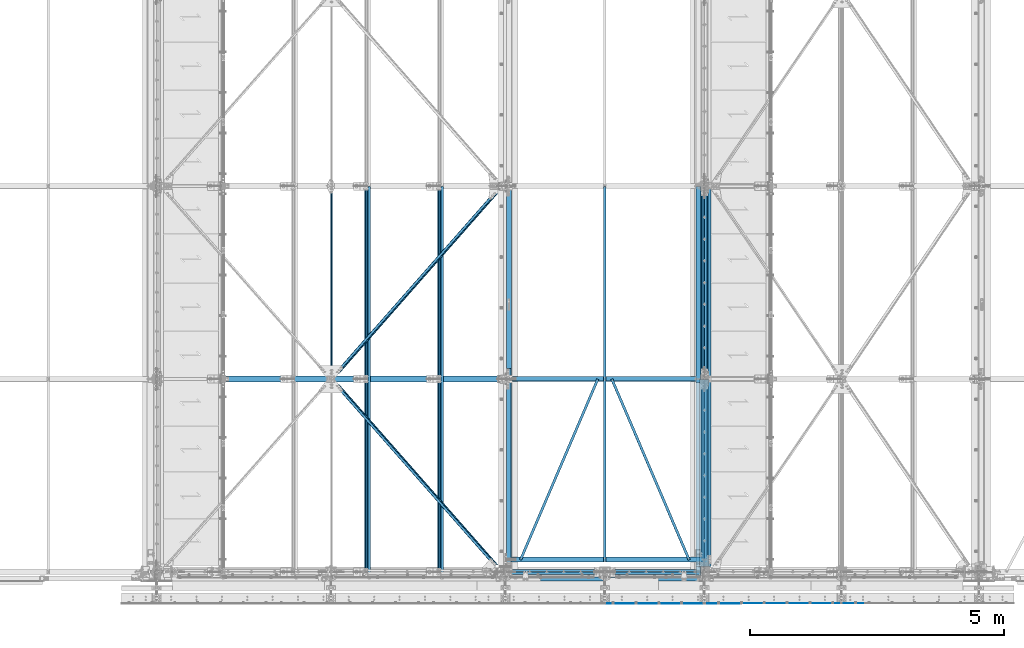
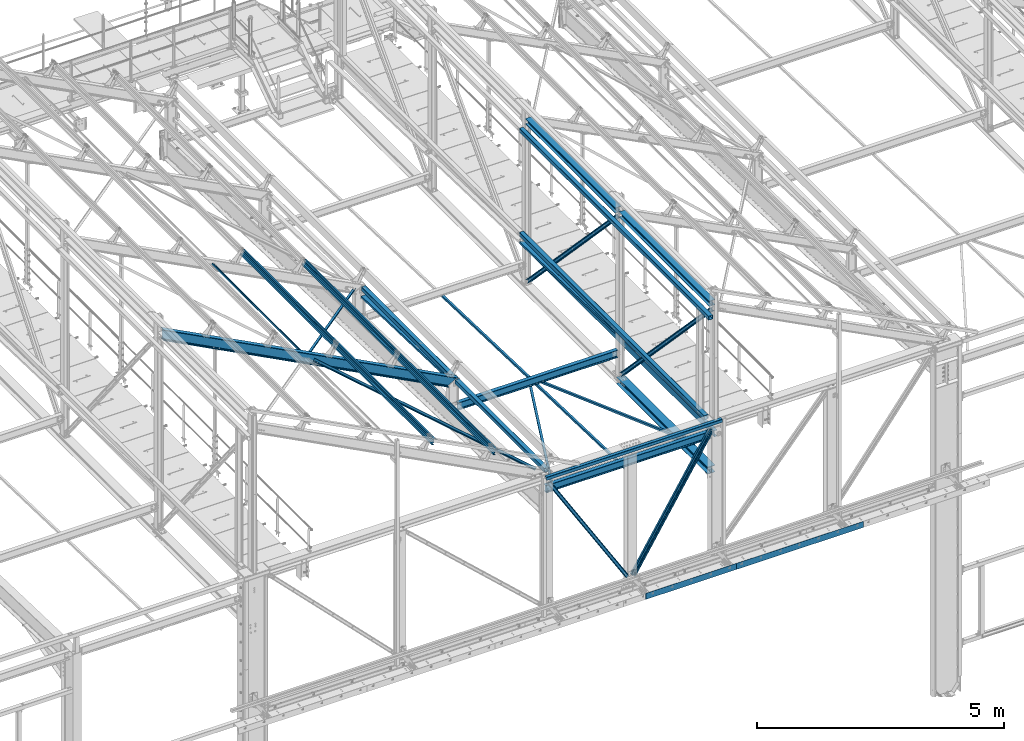
# One storey, part 47 of 496: 23 beams, 9 members, 32 elements without a shape of their own.
"""IFC2X3 building model written with IfcOpenShell, lengths in millimetres."""

from ifc_helpers import new_model, si_unit, frame, origin_with_axes, origin_2d_with_axis, place, context, subcontext, project, spatial, polyline, rectangle, hollow_rectangle, i_section, l_section, u_section, outline, extrude, clip, halfspace, material, type_object, element, aggregate, save


model = new_model("IFC2X3")

# Units and contexts
model_context = context("Model", 3, precision=1e-05, world=origin_with_axes())
body_context = subcontext(model_context, "Body", "Model", "MODEL_VIEW")
ifc_project = project(units=[si_unit("LENGTHUNIT", "METRE", prefix="MILLI"), si_unit("AREAUNIT", "SQUARE_METRE"), si_unit("VOLUMEUNIT", "CUBIC_METRE"), si_unit("MASSUNIT", "GRAM", prefix="KILO"), si_unit("TIMEUNIT", "SECOND"), si_unit("PLANEANGLEUNIT", "RADIAN"), si_unit("SOLIDANGLEUNIT", "STERADIAN"), si_unit("THERMODYNAMICTEMPERATUREUNIT", "DEGREE_CELSIUS"), si_unit("LUMINOUSINTENSITYUNIT", "LUMEN")], contexts=[model_context])

# Site, building, storey
site_placement = place(None, origin_with_axes())
site = spatial("IfcSite", under=ifc_project, at=site_placement, CompositionType="ELEMENT")
building_placement = place(site_placement, origin_with_axes())
building = spatial("IfcBuilding", under=site, at=building_placement, Name="Undefined", CompositionType="ELEMENT")
storey_placement = place(building_placement, origin_with_axes())
storey = spatial("IfcBuildingStorey", under=building, at=storey_placement, Name="Undefined", CompositionType="ELEMENT", Elevation=0.0)

# Assembly, beam
assembly_1_placement = place(storey_placement, origin_with_axes())
assembly_1 = element("IfcElementAssembly", 1, at=assembly_1_placement, inside=storey, AssemblyPlace="NOTDEFINED", PredefinedType="NOTDEFINED")
ifc_material_1 = material(Name="Undefined/S235-E24")
beam_type_1 = type_object("IfcBeamType", PredefinedType="NOTDEFINED")
beam_1_placement = place(assembly_1_placement, frame((19848.2097133607, 235.976054337025, 7837.48629341101), z_axis=(0.919534207042302, -0.392816044708112, 0.012344921990827), x_axis=(0.39300997707321, 0.919080459171206, -0.0288836890053805)))
beam_1 = element("IfcBeam", 2, at=beam_1_placement, type_object=beam_type_1, material=ifc_material_1, context=body_context, shape_type="SweptSolid", body=[
    extrude(l_section(Depth=50.0, Width=50.0, Thickness=5.0, FilletRadius=7.0, EdgeRadius=3.5, at=origin_2d_with_axis()), frame((3876.69700077137, -1.34499945929739e-14, -3.40701718119049e-12), z_axis=(-1.0, 0.0, 0.0), x_axis=(0.0, -1.0, 0.0)), (0.0, 0.0, 1.0), 3876.7),
])
aggregate(assembly_1, [beam_1])

assembly_2_placement = place(storey_placement, origin_with_axes())
assembly_2 = element("IfcElementAssembly", 3, at=assembly_2_placement, inside=storey, AssemblyPlace="NOTDEFINED", PredefinedType="NOTDEFINED")
beam_2_placement = place(assembly_2_placement, frame((23171.7903119741, 235.976054737208, 7837.48629340527), z_axis=(0.919534207042302, 0.392816044708111, -0.0123449219908271), x_axis=(-0.39300997707321, 0.919080459171207, -0.0288836890053805)))
beam_2 = element("IfcBeam", 4, at=beam_2_placement, type_object=beam_type_1, material=ifc_material_1, context=body_context, shape_type="SweptSolid", body=[
    extrude(l_section(Depth=50.0, Width=50.0, Thickness=5.0, FilletRadius=7.0, EdgeRadius=3.5, at=origin_2d_with_axis()), frame((3876.69700077137, -1.34499945929739e-14, -3.40701718119049e-12), z_axis=(-1.0, 0.0, 0.0), x_axis=(0.0, -1.0, 0.0)), (0.0, 0.0, 1.0), 3876.7),
])
aggregate(assembly_2, [beam_2])

assembly_3_placement = place(storey_placement, origin_with_axes())
assembly_3 = element("IfcElementAssembly", 5, at=assembly_3_placement, inside=storey, AssemblyPlace="NOTDEFINED", PredefinedType="NOTDEFINED")
beam_3_placement = place(assembly_3_placement, frame((21507.0000126668, 193.083339984078, 7838.83427099067), z_axis=(1.0, 0.0, 0.0), x_axis=(0.0, 0.999506556345274, -0.0314108870109058)))
beam_3 = element("IfcBeam", 6, at=beam_3_placement, type_object=beam_type_1, material=ifc_material_1, context=body_context, shape_type="SweptSolid", body=[
    extrude(l_section(Depth=50.0, Width=50.0, Thickness=5.0, FilletRadius=7.0, EdgeRadius=3.5, at=origin_2d_with_axis()), frame((7401.95936429781, -5.13614107098951e-14, 0.0), z_axis=(-1.0, 0.0, 0.0), x_axis=(0.0, -1.0, 0.0)), (0.0, 0.0, 1.0), 7401.96),
])
aggregate(assembly_3, [beam_3])

assembly_4_placement = place(storey_placement, origin_with_axes())
assembly_4 = element("IfcElementAssembly", 7, at=assembly_4_placement, inside=storey, AssemblyPlace="NOTDEFINED", PredefinedType="NOTDEFINED")
beam_type_2 = type_object("IfcBeamType", PredefinedType="NOTDEFINED")
beam_4_placement = place(assembly_4_placement, frame((19477.1831031286, 7597.88523553888, 8549.29591306557), z_axis=(0.46352885499701, 6.99999093634976e-09, 0.886081824994261), x_axis=(-0.624617894277257, -0.709285753314833, 0.326750985145042)))
beam_4 = element("IfcBeam", 8, at=beam_4_placement, type_object=beam_type_2, material=ifc_material_1, context=body_context, shape_type="Clipping", body=[
    clip(clip(extrude(l_section(Depth=60.0, Width=60.0, Thickness=6.0, FilletRadius=8.0, EdgeRadius=4.0, at=origin_2d_with_axis()), frame((5278.55461629117, -2.34983368195919e-13, 0.0), z_axis=(-1.0, 0.0, 0.0), x_axis=(0.0, -1.0, 0.0)), (0.0, 0.0, 1.0), 5199.61), halfspace(frame((5188.72403947743, 29.9999999858928, -29.9999505382657), z_axis=(-1.0, 0.0, 0.0), x_axis=(0.0, 0.0, 1.0)), True)), halfspace(frame((168.777987271034, -30.0000000492832, -29.9999736335085), z_axis=(1.0, 0.0, 0.0), x_axis=(0.0, 0.0, 1.0)), True)),
])
aggregate(assembly_4, [beam_4])

assembly_5_placement = place(storey_placement, origin_with_axes())
assembly_5 = element("IfcElementAssembly", 9, at=assembly_5_placement, inside=storey, AssemblyPlace="NOTDEFINED", PredefinedType="NOTDEFINED")
beam_5_placement = place(assembly_5_placement, frame((19477.1831039176, 2.11476189271161, 8549.295912599), z_axis=(-0.628485325518915, -0.704921099379824, 0.328774146271455), x_axis=(-0.624617921816656, 0.709285727791797, 0.326750987904095)))
beam_5 = element("IfcBeam", 10, at=beam_5_placement, type_object=beam_type_2, material=ifc_material_1, context=body_context, shape_type="Clipping", body=[
    clip(clip(extrude(l_section(Depth=60.0, Width=60.0, Thickness=6.0, FilletRadius=8.0, EdgeRadius=4.0, at=origin_2d_with_axis()), frame((5278.55476626172, 5.86037303824862e-13, 1.46509325956215e-13), z_axis=(-1.0, 0.0, 0.0), x_axis=(0.0, -1.0, 0.0)), (0.0, 0.0, 1.0), 5199.6), halfspace(frame((5188.72418918782, 29.9999489796537, -30.0000000061282), z_axis=(1.0, 0.0, 0.0), x_axis=(0.0, -1.0, 0.0)), False)), halfspace(frame((168.785817419039, 29.9999318120026, 30.0077309302196), z_axis=(-1.0, 0.0, 0.0), x_axis=(0.0, -1.0, 0.0)), False)),
])
aggregate(assembly_5, [beam_5])

assembly_6_placement = place(storey_placement, origin_with_axes())
assembly_6 = element("IfcElementAssembly", 11, at=assembly_6_placement, inside=storey, Name="SUPPORT", AssemblyPlace="NOTDEFINED", PredefinedType="NOTDEFINED")
beam_type_3 = type_object("IfcBeamType", PredefinedType="NOTDEFINED")
beam_6_placement = place(assembly_6_placement, frame((21514.9999940283, -622.0, 5154.99824538435), z_axis=(0.0, 0.0, 1.0), x_axis=(1.0, 0.0, 0.0)))
beam_6 = element("IfcBeam", 12, at=beam_6_placement, type_object=beam_type_3, material=ifc_material_1, Name="SUPPORT", context=body_context, shape_type="SweptSolid", body=[
    extrude(rectangle(XDim=4.0, YDim=150.0, at=origin_2d_with_axis()), frame((2125.00001791507, 0.0, 0.0), z_axis=(-1.0, 0.0, 0.0), x_axis=(0.0, -1.0, 0.0)), (0.0, 0.0, 1.0), 2125.0),
])
aggregate(assembly_6, [beam_6])

assembly_7_placement = place(storey_placement, origin_with_axes())
assembly_7 = element("IfcElementAssembly", 13, at=assembly_7_placement, inside=storey, Name="SUPPORT", AssemblyPlace="NOTDEFINED", PredefinedType="NOTDEFINED")
beam_7_placement = place(assembly_7_placement, frame((23640.0000119434, -622.0, 5154.99824538435), z_axis=(0.0, 0.0, 1.0), x_axis=(1.0, 0.0, 0.0)))
beam_7 = element("IfcBeam", 14, at=beam_7_placement, type_object=beam_type_3, material=ifc_material_1, Name="SUPPORT", context=body_context, shape_type="SweptSolid", body=[
    extrude(rectangle(XDim=4.0, YDim=150.0, at=origin_2d_with_axis()), frame((2964.99999402831, 0.0, 0.0), z_axis=(-1.0, 0.0, 0.0), x_axis=(0.0, -1.0, 0.0)), (0.0, 0.0, 1.0), 2965.0),
])
aggregate(assembly_7, [beam_7])

assembly_8_placement = place(storey_placement, origin_with_axes())
assembly_8 = element("IfcElementAssembly", 15, at=assembly_8_placement, inside=storey, Name="LISSE", AssemblyPlace="NOTDEFINED", PredefinedType="NOTDEFINED")
beam_type_4 = type_object("IfcBeamType", PredefinedType="NOTDEFINED")
beam_8_placement = place(assembly_8_placement, frame((23353.5001162792, 3730.03454686984, 8413.05496432255), z_axis=(1.0, 0.0, 0.0), x_axis=(0.0, 0.999506445341009, -0.0314144190107172)))
beam_8 = element("IfcBeam", 16, at=beam_8_placement, type_object=beam_type_4, material=ifc_material_1, Name="LISSE", context=body_context, shape_type="SweptSolid", body=[
    extrude(u_section(Depth=100.0, FlangeWidth=50.0, WebThickness=4.0, FlangeThickness=4.0, at=origin_2d_with_axis()), frame((3864.8364307433, 0.0, 0.0), z_axis=(-1.0, 0.0, 0.0), x_axis=(0.0, -1.0, 0.0)), (0.0, 0.0, 1.0), 3864.84),
])
aggregate(assembly_8, [beam_8])

assembly_9_placement = place(storey_placement, origin_with_axes())
assembly_9 = element("IfcElementAssembly", 17, at=assembly_9_placement, inside=storey, Name="LISSE", AssemblyPlace="NOTDEFINED", PredefinedType="NOTDEFINED")
beam_9_placement = place(assembly_9_placement, frame((19620.0000000007, 3800.0, 8410.85601504986), z_axis=(1.0, 0.0, 0.0), x_axis=(0.0, 0.999506445341009, -0.0314144190107172)))
beam_9 = element("IfcBeam", 18, at=beam_9_placement, type_object=beam_type_4, material=ifc_material_1, Name="LISSE", context=body_context, shape_type="Clipping", body=[
    clip(clip(extrude(u_section(Depth=100.0, FlangeWidth=50.0, WebThickness=4.0, FlangeThickness=4.0, at=origin_2d_with_axis()), frame((3738.43154409699, 2.59405798515091e-14, 0.0), z_axis=(-1.0, 0.0, 0.0), x_axis=(0.0, -1.0, 0.0)), (0.0, 0.0, 1.0), 3536.42), halfspace(frame((3735.73414698921, 35.3226290313178, 49.9999999992579), z_axis=(-0.999506472307554, -0.0314135610096736, 0.0), x_axis=(0.0, 0.0, 1.0)), True)), halfspace(frame((202.484021196273, 35.5224298009161, 49.9999999992579), z_axis=(0.999506472307554, 0.0314135610096964, 0.0), x_axis=(0.0, 0.0, 1.0)), True)),
])
aggregate(assembly_9, [beam_9])

assembly_10_placement = place(storey_placement, origin_with_axes())
assembly_10 = element("IfcElementAssembly", 19, at=assembly_10_placement, inside=storey, Name="LISSE", AssemblyPlace="NOTDEFINED", PredefinedType="NOTDEFINED")
beam_type_5 = type_object("IfcBeamType", PredefinedType="NOTDEFINED")
beam_10_placement = place(assembly_10_placement, frame((23353.5000012916, -70.0000009854945, 11069.999999999), z_axis=(0.0, 0.0, -1.0), x_axis=(0.0, 1.0, 0.0)))
beam_10 = element("IfcBeam", 20, at=beam_10_placement, type_object=beam_type_5, material=ifc_material_1, Name="LISSE", context=body_context, shape_type="SweptSolid", body=[
    extrude(hollow_rectangle(XDim=100.0, YDim=100.0, WallThickness=4.0, InnerFilletRadius=4.0, OuterFilletRadius=8.0, at=origin_2d_with_axis()), frame((7664.99999999271, 0.0, 0.0), z_axis=(-1.0, 0.0, 0.0), x_axis=(0.0, -1.0, 0.0)), (0.0, 0.0, 1.0), 7665.0),
])
aggregate(assembly_10, [beam_10])

assembly_11_placement = place(storey_placement, origin_with_axes())
assembly_11 = element("IfcElementAssembly", 21, at=assembly_11_placement, inside=storey, Name="LISSE", AssemblyPlace="NOTDEFINED", PredefinedType="NOTDEFINED")
beam_11_placement = place(assembly_11_placement, frame((23353.5, 110.0, 8500.0), z_axis=(0.0, 0.0, 1.0), x_axis=(0.0, 1.0, 0.0)))
beam_11 = element("IfcBeam", 22, at=beam_11_placement, type_object=beam_type_5, material=ifc_material_1, Name="LISSE", context=body_context, shape_type="SweptSolid", body=[
    extrude(hollow_rectangle(XDim=100.0, YDim=100.0, WallThickness=4.0, InnerFilletRadius=4.0, OuterFilletRadius=8.0, at=origin_2d_with_axis()), frame((7485.0, 0.0, 0.0), z_axis=(-1.0, 0.0, 0.0), x_axis=(0.0, -1.0, 0.0)), (0.0, 0.0, 1.0), 7485.0),
])
aggregate(assembly_11, [beam_11])

assembly_12_placement = place(storey_placement, origin_with_axes())
assembly_12 = element("IfcElementAssembly", 23, at=assembly_12_placement, inside=storey, Name="LISSE", AssemblyPlace="NOTDEFINED", PredefinedType="NOTDEFINED")
beam_12_placement = place(assembly_12_placement, frame((19619.9999999823, 3870.0, 8500.0), z_axis=(0.0, 0.0, 1.0), x_axis=(0.0, 1.0, 0.0)))
beam_12 = element("IfcBeam", 24, at=beam_12_placement, type_object=beam_type_5, material=ifc_material_1, Name="LISSE", context=body_context, shape_type="SweptSolid", body=[
    extrude(hollow_rectangle(XDim=100.0, YDim=100.0, WallThickness=4.0, InnerFilletRadius=4.0, OuterFilletRadius=8.0, at=origin_2d_with_axis()), frame((3660.0, 0.0, 0.0), z_axis=(-1.0, 0.0, 0.0), x_axis=(0.0, -1.0, 0.0)), (0.0, 0.0, 1.0), 3660.0),
])
aggregate(assembly_12, [beam_12])

assembly_13_placement = place(storey_placement, origin_with_axes())
assembly_13 = element("IfcElementAssembly", 25, at=assembly_13_placement, inside=storey, Name="LISSE", AssemblyPlace="NOTDEFINED", PredefinedType="NOTDEFINED")
beam_13_placement = place(assembly_13_placement, frame((19619.9999999823, 110.0, 8500.0), z_axis=(0.0, 0.0, 1.0), x_axis=(0.0, 1.0, 0.0)))
beam_13 = element("IfcBeam", 26, at=beam_13_placement, type_object=beam_type_5, material=ifc_material_1, Name="LISSE", context=body_context, shape_type="SweptSolid", body=[
    extrude(hollow_rectangle(XDim=100.0, YDim=100.0, WallThickness=4.0, InnerFilletRadius=4.0, OuterFilletRadius=8.0, at=origin_2d_with_axis()), frame((3620.0, 0.0, 0.0), z_axis=(-1.0, 0.0, 0.0), x_axis=(0.0, -1.0, 0.0)), (0.0, 0.0, 1.0), 3620.0),
])
aggregate(assembly_13, [beam_13])

assembly_14_placement = place(storey_placement, origin_with_axes())
assembly_14 = element("IfcElementAssembly", 27, at=assembly_14_placement, inside=storey, AssemblyPlace="NOTDEFINED", PredefinedType="NOTDEFINED")
beam_type_6 = type_object("IfcBeamType", PredefinedType="NOTDEFINED")
beam_14_placement = place(assembly_14_placement, frame((16124.2705700824, 7579.99999999632, 10291.9905299858), z_axis=(-0.886082013248113, 9.38091927309869e-07, 0.463528495129794), x_axis=(-8.13000000285402e-07, -0.999999999999581, 4.20999999948846e-07)))
beam_14 = element("IfcBeam", 28, at=beam_14_placement, type_object=beam_type_6, material=ifc_material_1, context=body_context, shape_type="SweptSolid", body=[
    extrude(hollow_rectangle(XDim=40.0, YDim=40.0, WallThickness=4.0, InnerFilletRadius=4.0, OuterFilletRadius=8.0, at=origin_2d_with_axis()), frame((3700.00150276796, -3.63797900296816e-12, -3.9175289721686e-19), z_axis=(-1.0, 0.0, 0.0), x_axis=(0.0, -1.0, 0.0)), (0.0, 0.0, 1.0), 3700.0),
])
aggregate(assembly_14, [beam_14])

assembly_15_placement = place(storey_placement, origin_with_axes())
assembly_15 = element("IfcElementAssembly", 29, at=assembly_15_placement, inside=storey, AssemblyPlace="NOTDEFINED", PredefinedType="NOTDEFINED")
ifc_material_2 = material(Name="Undefined/S275-E28")
beam_type_7 = type_object("IfcBeamType", Name="HEA140", PredefinedType="NOTDEFINED")
beam_15_placement = place(assembly_15_placement, frame((23473.5, 3725.0, 11302.5), z_axis=(0.0, 0.0, 1.0), x_axis=(0.0, -1.0, 0.0)))
beam_15 = element("IfcBeam", 30, at=beam_15_placement, type_object=beam_type_7, material=ifc_material_2, ObjectType="HEA140", context=body_context, shape_type="SweptSolid", body=[
    extrude(i_section(OverallWidth=140.0, OverallDepth=133.0, WebThickness=5.5, FlangeThickness=8.5, FilletRadius=12.0, at=origin_2d_with_axis()), frame((3650.0, 0.0, 0.0), z_axis=(-1.0, 0.0, 0.0), x_axis=(0.0, -1.0, 0.0)), (0.0, 0.0, 1.0), 3650.0),
])
aggregate(assembly_15, [beam_15])

assembly_16_placement = place(storey_placement, origin_with_axes())
assembly_16 = element("IfcElementAssembly", 31, at=assembly_16_placement, inside=storey, AssemblyPlace="NOTDEFINED", PredefinedType="NOTDEFINED")
beam_16_placement = place(assembly_16_placement, frame((23473.5, 7525.0, 11302.5), z_axis=(0.0, 0.0, 1.0), x_axis=(0.0, -1.0, 0.0)))
beam_16 = element("IfcBeam", 32, at=beam_16_placement, type_object=beam_type_7, material=ifc_material_2, ObjectType="HEA140", context=body_context, shape_type="SweptSolid", body=[
    extrude(i_section(OverallWidth=140.0, OverallDepth=133.0, WebThickness=5.5, FlangeThickness=8.5, FilletRadius=12.0, at=origin_2d_with_axis()), frame((3650.0, 0.0, 0.0), z_axis=(-1.0, 0.0, 0.0), x_axis=(0.0, -1.0, 0.0)), (0.0, 0.0, 1.0), 3650.0),
])
aggregate(assembly_16, [beam_16])

assembly_17_placement = place(storey_placement, origin_with_axes())
assembly_17 = element("IfcElementAssembly", 33, at=assembly_17_placement, inside=storey, AssemblyPlace="NOTDEFINED", PredefinedType="NOTDEFINED")
beam_type_8 = type_object("IfcBeamType", Name="HEA180", PredefinedType="NOTDEFINED")
beam_17_placement = place(assembly_17_placement, frame((23470.0, 3794.99999867492, 7164.50000000038), z_axis=(0.0, 0.0, 1.0), x_axis=(0.0, -1.0, 0.0)))
beam_17 = element("IfcBeam", 34, at=beam_17_placement, type_object=beam_type_8, material=ifc_material_2, ObjectType="HEA180", context=body_context, shape_type="SweptSolid", body=[
    extrude(i_section(OverallWidth=180.0, OverallDepth=171.0, WebThickness=6.0, FlangeThickness=9.5, FilletRadius=15.0, at=origin_2d_with_axis()), frame((3689.99694071491, 0.0, 0.0), z_axis=(-1.0, 0.0, 0.0), x_axis=(0.0, -1.0, 0.0)), (0.0, 0.0, 1.0), 3690.0),
])
aggregate(assembly_17, [beam_17])

assembly_18_placement = place(storey_placement, origin_with_axes())
assembly_18 = element("IfcElementAssembly", 35, at=assembly_18_placement, inside=storey, AssemblyPlace="NOTDEFINED", PredefinedType="NOTDEFINED")
beam_type_9 = type_object("IfcBeamType", PredefinedType="NOTDEFINED")
beam_18_placement = place(assembly_18_placement, frame((23571.5000574129, 105.000000531447, 8025.0), z_axis=(0.0, 0.0, 1.0), x_axis=(0.0, 1.0, 0.0)))
beam_18 = element("IfcBeam", 36, at=beam_18_placement, type_object=beam_type_9, material=ifc_material_1, context=body_context, shape_type="SweptSolid", body=[
    extrude(u_section(Depth=150.0, FlangeWidth=70.0, WebThickness=5.0, FlangeThickness=5.0, at=origin_2d_with_axis()), frame((7490.00000100342, 2.47823311554088e-20, 0.0), z_axis=(-1.0, 0.0, 0.0), x_axis=(0.0, -1.0, 0.0)), (0.0, 0.0, 1.0), 7490.0),
])
aggregate(assembly_18, [beam_18])

assembly_19_placement = place(storey_placement, origin_with_axes())
assembly_19 = element("IfcElementAssembly", 37, at=assembly_19_placement, inside=storey, Name="SHED", AssemblyPlace="NOTDEFINED", PredefinedType="NOTDEFINED")
beam_type_10 = type_object("IfcBeamType", PredefinedType="NOTDEFINED")
beam_19_placement = place(assembly_19_placement, frame((16833.5855159203, -154.999920381521, 10327.2156396591), z_axis=(0.46352885499701, 6.99999093634976e-09, 0.886081824994261), x_axis=(0.0, 1.0, 0.0)))
beam_19 = element("IfcBeam", 38, at=beam_19_placement, type_object=beam_type_10, material=ifc_material_1, Name="SHED", context=body_context, shape_type="SweptSolid", body=[
    extrude(outline(polyline([(-27.9999999860338, 36.0000000101354), (-27.999999986052, 70.0000000101354), (28.0000000138389, 70.0000000101209), (28.0000000138425, 58.0000000101209), (26.5000000138534, 58.0000000101209), (26.5000000138352, 68.5000000101172), (-26.4999999860593, 68.5000000101354), (-26.4999999860338, 36.7000007730749), (-1.49999998607018, 15.6999998194005), (-1.49999998605563, -15.6999997991297), (-26.4999999859974, -36.7000007527895), (-26.4999999859829, -68.49999998985), (26.5000000139153, -68.4999999898646), (26.500000013908, -57.9999999898646), (28.0000000139116, -57.9999999898646), (28.0000000139153, -69.9999999898646), (-27.9999999859756, -69.99999998985), (-27.9999999859901, -35.99999998985), (-2.99999998605927, -14.9999999898646), (-2.9999999860629, 15.0000000101354), (-27.9999999860338, 36.0000000101354)])), frame((7750.00000000006, -3.63797880548905e-12, 0.0), z_axis=(-1.0, 0.0, 0.0), x_axis=(0.0, -1.0, 0.0)), (0.0, 0.0, 1.0), 7750.0),
])
aggregate(assembly_19, [beam_19])

assembly_20_placement = place(storey_placement, origin_with_axes())
assembly_20 = element("IfcElementAssembly", 39, at=assembly_20_placement, inside=storey, Name="SHED", AssemblyPlace="NOTDEFINED", PredefinedType="NOTDEFINED")
beam_20_placement = place(assembly_20_placement, frame((18270.8856646988, -154.999920381521, 9575.33349724936), z_axis=(0.46352885499701, 6.99999093634976e-09, 0.886081824994261), x_axis=(0.0, 1.0, 0.0)))
beam_20 = element("IfcBeam", 40, at=beam_20_placement, type_object=beam_type_10, material=ifc_material_1, Name="SHED", context=body_context, shape_type="SweptSolid", body=[
    extrude(outline(polyline([(-27.9999999860338, 36.0000000101354), (-27.999999986052, 70.0000000101354), (28.0000000138389, 70.0000000101209), (28.0000000138425, 58.0000000101209), (26.5000000138534, 58.0000000101209), (26.5000000138352, 68.5000000101172), (-26.4999999860593, 68.5000000101354), (-26.4999999860338, 36.7000007730749), (-1.49999998607018, 15.6999998194005), (-1.49999998605563, -15.6999997991297), (-26.4999999859974, -36.7000007527895), (-26.4999999859829, -68.49999998985), (26.5000000139153, -68.4999999898646), (26.500000013908, -57.9999999898646), (28.0000000139116, -57.9999999898646), (28.0000000139153, -69.9999999898646), (-27.9999999859756, -69.99999998985), (-27.9999999859901, -35.99999998985), (-2.99999998605927, -14.9999999898646), (-2.9999999860629, 15.0000000101354), (-27.9999999860338, 36.0000000101354)])), frame((7750.00000000006, -3.63797880548905e-12, 0.0), z_axis=(-1.0, 0.0, 0.0), x_axis=(0.0, -1.0, 0.0)), (0.0, 0.0, 1.0), 7750.0),
])
aggregate(assembly_20, [beam_20])

# Assembly, member
assembly_21_placement = place(storey_placement, origin_with_axes())
assembly_21 = element("IfcElementAssembly", 41, at=assembly_21_placement, inside=storey, AssemblyPlace="NOTDEFINED", PredefinedType="NOTDEFINED")
member_type_1 = type_object("IfcMemberType", Name="UPN80", PredefinedType="NOTDEFINED")
member_1_placement = place(assembly_21_placement, frame((23497.4999999937, 7599.99999999989, 7250.0), z_axis=(0.0, -0.723792357104951, -0.69001784310006), x_axis=(0.0, -0.690017790887057, 0.723792406881522)))
member_1 = element("IfcMember", 42, at=member_1_placement, type_object=member_type_1, material=ifc_material_2, ObjectType="UPN80", context=body_context, shape_type="Clipping", body=[
    clip(clip(extrude(u_section(Depth=80.0, FlangeWidth=45.0, WebThickness=6.0, FlangeThickness=8.0, FilletRadius=8.0, EdgeRadius=4.0, FlangeSlope=0.0798299857122373, at=origin_2d_with_axis()), frame((5467.81196900541, 0.0, 0.0), z_axis=(-1.0, 0.0, 0.0), x_axis=(0.0, -1.0, 0.0)), (0.0, 0.0, 1.0), 5428.52), halfspace(frame((5387.10413924701, 27.4999999683605, -40.0000000000014), z_axis=(-1.0, 0.0, 0.0), x_axis=(0.0, 1.0, 0.0)), True)), halfspace(frame((119.999999989826, 27.5000000297296, 39.9999985196016), z_axis=(1.0, 0.0, 0.0), x_axis=(0.0, 1.0, 0.0)), True)),
])
aggregate(assembly_21, [member_1])

assembly_22_placement = place(storey_placement, origin_with_axes())
assembly_22 = element("IfcElementAssembly", 43, at=assembly_22_placement, inside=storey, AssemblyPlace="NOTDEFINED", PredefinedType="NOTDEFINED")
member_2_placement = place(assembly_22_placement, frame((23442.4999999902, 3800.00000035527, 11235.9999997217), z_axis=(0.0, -0.723792357104951, -0.69001784310006), x_axis=(0.0, 0.69001784310006, -0.723792357104951)))
member_2 = element("IfcMember", 44, at=member_2_placement, type_object=member_type_1, material=ifc_material_2, ObjectType="UPN80", context=body_context, shape_type="Clipping", body=[
    clip(clip(extrude(u_section(Depth=80.0, FlangeWidth=45.0, WebThickness=6.0, FlangeThickness=8.0, FilletRadius=8.0, EdgeRadius=4.0, FlangeSlope=0.0798299857122373, at=origin_2d_with_axis()), frame((5467.81196900541, 0.0, 0.0), z_axis=(-1.0, 0.0, 0.0), x_axis=(0.0, -1.0, 0.0)), (0.0, 0.0, 1.0), 5428.52), halfspace(frame((5387.10413923787, 27.5000000297259, 39.9999976635263), z_axis=(-1.0, 0.0, 0.0), x_axis=(0.0, -1.0, 0.0)), True)), halfspace(frame((119.999999997919, 27.49999999375, -39.9999989691296), z_axis=(1.0, 0.0, 0.0), x_axis=(0.0, -1.0, 0.0)), True)),
])
aggregate(assembly_22, [member_2])

assembly_23_placement = place(storey_placement, origin_with_axes())
assembly_23 = element("IfcElementAssembly", 45, at=assembly_23_placement, inside=storey, AssemblyPlace="NOTDEFINED", PredefinedType="NOTDEFINED")
member_3_placement = place(assembly_23_placement, frame((23497.5000000055, 3799.99999999888, 7250.0), z_axis=(0.0, -0.723792905193063, -0.690017268184054), x_axis=(0.0, -0.690017254881077, 0.72379291787526)))
member_3 = element("IfcMember", 46, at=member_3_placement, type_object=member_type_1, material=ifc_material_2, ObjectType="UPN80", context=body_context, shape_type="Clipping", body=[
    clip(clip(extrude(u_section(Depth=80.0, FlangeWidth=45.0, WebThickness=6.0, FlangeThickness=8.0, FilletRadius=8.0, EdgeRadius=4.0, FlangeSlope=0.0798299857122373, at=origin_2d_with_axis()), frame((5467.80815243543, -3.63797880709171e-12, 1.21301902702628e-12), z_axis=(-1.0, 0.0, 0.0), x_axis=(0.0, -1.0, 0.0)), (0.0, 0.0, 1.0), 5428.52), halfspace(frame((5387.10032826796, 27.5000000054679, -39.9999987246501), z_axis=(-1.0, 0.0, 0.0), x_axis=(0.0, 1.0, 0.0)), True)), halfspace(frame((119.999999989826, 27.5000000297296, 39.9999985196016), z_axis=(1.0, 0.0, 0.0), x_axis=(0.0, 1.0, 0.0)), True)),
])
aggregate(assembly_23, [member_3])

assembly_24_placement = place(storey_placement, origin_with_axes())
assembly_24 = element("IfcElementAssembly", 47, at=assembly_24_placement, inside=storey, AssemblyPlace="NOTDEFINED", PredefinedType="NOTDEFINED")
member_4_placement = place(assembly_24_placement, frame((23442.4999999925, 0.00552265711468181, 11235.9999997217), z_axis=(0.0, -0.723792905193063, -0.690017268184054), x_axis=(0.0, 0.690017268184055, -0.723792905193063)))
member_4 = element("IfcMember", 48, at=member_4_placement, type_object=member_type_1, material=ifc_material_2, ObjectType="UPN80", context=body_context, shape_type="Clipping", body=[
    clip(clip(extrude(u_section(Depth=80.0, FlangeWidth=45.0, WebThickness=6.0, FlangeThickness=8.0, FilletRadius=8.0, EdgeRadius=4.0, FlangeSlope=0.0798299857122373, at=origin_2d_with_axis()), frame((5467.80815243543, -3.63797880709171e-12, 1.21301902702628e-12), z_axis=(-1.0, 0.0, 0.0), x_axis=(0.0, -1.0, 0.0)), (0.0, 0.0, 1.0), 5428.52), halfspace(frame((5387.10032827843, 27.5000000074579, 40.0), z_axis=(-1.0, 0.0, 0.0), x_axis=(0.0, -1.0, 0.0)), True)), halfspace(frame((119.999999997919, 27.49999999375, -39.9999989691296), z_axis=(1.0, 0.0, 0.0), x_axis=(0.0, -1.0, 0.0)), True)),
])
aggregate(assembly_24, [member_4])

assembly_25_placement = place(storey_placement, origin_with_axes())
assembly_25 = element("IfcElementAssembly", 49, at=assembly_25_placement, inside=storey, AssemblyPlace="NOTDEFINED", PredefinedType="NOTDEFINED")
member_5_placement = place(assembly_25_placement, frame((21509.9998361814, 27.4999999962392, 5190.00068841224), z_axis=(0.850550854129932, 0.0, 0.525892807080343), x_axis=(-0.525892804015426, 0.0, 0.85055085602496)))
member_5 = element("IfcMember", 50, at=member_5_placement, type_object=member_type_1, material=ifc_material_2, ObjectType="UPN80", context=body_context, shape_type="Clipping", body=[
    clip(clip(extrude(u_section(Depth=80.0, FlangeWidth=45.0, WebThickness=6.0, FlangeThickness=8.0, FilletRadius=8.0, EdgeRadius=4.0, FlangeSlope=0.0798299857122373, at=origin_2d_with_axis()), frame((3679.2782996934, 0.0, 0.0), z_axis=(-1.0, 0.0, 0.0), x_axis=(0.0, -1.0, 0.0)), (0.0, 0.0, 1.0), 3631.56), halfspace(frame((3606.9948486703, 27.4999999962392, -40.0000002188754), z_axis=(1.0, 0.0, 0.0), x_axis=(0.0, 0.0, 1.0)), False)), halfspace(frame((119.999999997919, 27.49999999375, -39.9999989691296), z_axis=(1.0, 0.0, 0.0), x_axis=(0.0, 0.0, 1.0)), True)),
])
aggregate(assembly_25, [member_5])

assembly_26_placement = place(storey_placement, origin_with_axes())
assembly_26 = element("IfcElementAssembly", 51, at=assembly_26_placement, inside=storey, AssemblyPlace="NOTDEFINED", PredefinedType="NOTDEFINED")
member_6_placement = place(assembly_26_placement, frame((19550.0000046662, -27.5000000023122, 8359.99931025349), z_axis=(0.850550854129932, 0.0, 0.525892807080343), x_axis=(0.525892807080343, 0.0, -0.850550854129932)))
member_6 = element("IfcMember", 52, at=member_6_placement, type_object=member_type_1, material=ifc_material_2, ObjectType="UPN80", context=body_context, shape_type="Clipping", body=[
    clip(clip(extrude(u_section(Depth=80.0, FlangeWidth=45.0, WebThickness=6.0, FlangeThickness=8.0, FilletRadius=8.0, EdgeRadius=4.0, FlangeSlope=0.0798299857122373, at=origin_2d_with_axis()), frame((3679.2782996934, 0.0, 0.0), z_axis=(-1.0, 0.0, 0.0), x_axis=(0.0, -1.0, 0.0)), (0.0, 0.0, 1.0), 3631.56), halfspace(frame((3606.9948486703, 27.4999999962392, -40.0000002188754), z_axis=(-1.0, 0.0, 0.0), x_axis=(0.0, 0.0, 1.0)), True)), halfspace(frame((119.999999997919, 27.49999999375, -39.9999989691296), z_axis=(-1.0, 0.0, 0.0), x_axis=(0.0, 0.0, 1.0)), False)),
])
aggregate(assembly_26, [member_6])

assembly_27_placement = place(storey_placement, origin_with_axes())
assembly_27 = element("IfcElementAssembly", 53, at=assembly_27_placement, inside=storey, AssemblyPlace="NOTDEFINED", PredefinedType="NOTDEFINED")
member_7_placement = place(assembly_27_placement, frame((23470.0000047936, 27.5000000026857, 8359.99930913965), z_axis=(-0.85055080407058, 0.0, 0.525892888043649), x_axis=(-0.525892894896888, 0.0, -0.850550799833244)))
member_7 = element("IfcMember", 54, at=member_7_placement, type_object=member_type_1, material=ifc_material_2, ObjectType="UPN80", context=body_context, shape_type="Clipping", body=[
    clip(clip(extrude(u_section(Depth=80.0, FlangeWidth=45.0, WebThickness=6.0, FlangeThickness=8.0, FilletRadius=8.0, EdgeRadius=4.0, FlangeSlope=0.0798299857122373, at=origin_2d_with_axis()), frame((3679.27848179246, 0.0, 4.08481968449388e-13), z_axis=(-1.0, 0.0, 0.0), x_axis=(0.0, -1.0, 0.0)), (0.0, 0.0, 1.0), 3631.56), halfspace(frame((3606.99502519585, 27.5000000026857, 40.0000000424661), z_axis=(-1.0, 0.0, 0.0), x_axis=(0.0, 0.0, -1.0)), True)), halfspace(frame((119.999999997919, 27.49999999375, -39.9999989691296), z_axis=(1.0, 0.0, 0.0), x_axis=(0.0, 0.0, 1.0)), True)),
])
aggregate(assembly_27, [member_7])

assembly_28_placement = place(storey_placement, origin_with_axes())
assembly_28 = element("IfcElementAssembly", 55, at=assembly_28_placement, inside=storey, AssemblyPlace="NOTDEFINED", PredefinedType="NOTDEFINED")
member_8_placement = place(assembly_28_placement, frame((21509.9998359596, -27.5000000006007, 5190.00068831893), z_axis=(-0.85055080407058, 0.0, 0.525892888043649), x_axis=(0.525892888043649, 0.0, 0.85055080407058)))
member_8 = element("IfcMember", 56, at=member_8_placement, type_object=member_type_1, material=ifc_material_2, ObjectType="UPN80", context=body_context, shape_type="Clipping", body=[
    clip(clip(extrude(u_section(Depth=80.0, FlangeWidth=45.0, WebThickness=6.0, FlangeThickness=8.0, FilletRadius=8.0, EdgeRadius=4.0, FlangeSlope=0.0798299857122373, at=origin_2d_with_axis()), frame((3679.27848179246, 0.0, 4.08481968449388e-13), z_axis=(-1.0, 0.0, 0.0), x_axis=(0.0, -1.0, 0.0)), (0.0, 0.0, 1.0), 3631.56), halfspace(frame((3606.99502517976, 27.5000000006007, -40.0), z_axis=(-1.0, 0.0, 0.0), x_axis=(0.0, 0.0, 1.0)), True)), halfspace(frame((119.999999989826, 27.5000000297296, 39.9999985196016), z_axis=(1.0, 0.0, 0.0), x_axis=(0.0, 0.0, -1.0)), True)),
])
aggregate(assembly_28, [member_8])

# Assembly, beam
assembly_29_placement = place(storey_placement, origin_with_axes())
assembly_29 = element("IfcElementAssembly", 57, at=assembly_29_placement, inside=storey, Name="LISSE", AssemblyPlace="NOTDEFINED", PredefinedType="NOTDEFINED")
beam_type_11 = type_object("IfcBeamType", PredefinedType="NOTDEFINED")
beam_21_placement = place(assembly_29_placement, frame((19454.999999978, -139.999999992671, 8509.99999998238), z_axis=(0.0, 0.0, 1.0), x_axis=(1.0, 0.0, 0.0)))
beam_21 = element("IfcBeam", 58, at=beam_21_placement, type_object=beam_type_11, material=ifc_material_1, Name="LISSE", context=body_context, shape_type="SweptSolid", body=[
    extrude(hollow_rectangle(XDim=80.0, YDim=80.0, WallThickness=4.0, InnerFilletRadius=4.0, OuterFilletRadius=8.0, at=origin_2d_with_axis()), frame((4110.0, 0.0, 0.0), z_axis=(-1.0, 0.0, 0.0), x_axis=(0.0, -1.0, 0.0)), (0.0, 0.0, 1.0), 4110.0),
])
aggregate(assembly_29, [beam_21])

# Assembly, member
assembly_30_placement = place(storey_placement, origin_with_axes())
assembly_30 = element("IfcElementAssembly", 59, at=assembly_30_placement, inside=storey, Name="TRAVERSE SHED", AssemblyPlace="NOTDEFINED", PredefinedType="NOTDEFINED")
member_type_2 = type_object("IfcMemberType", Name="IPE240", PredefinedType="NOTDEFINED")
member_9_placement = place(assembly_30_placement, frame((12694.3765846431, 3799.99999999682, 12063.6701562877), z_axis=(0.46352885499701, 6.99999093634976e-09, 0.886081824994261), x_axis=(0.886081856298361, 3.500000375794e-08, -0.463528795156082)))
member_9 = element("IfcMember", 60, at=member_9_placement, type_object=member_type_2, material=ifc_material_2, Name="TRAVERSE SHED", ObjectType="IPE240", context=body_context, shape_type="Clipping", body=[
    clip(clip(extrude(i_section(OverallWidth=120.0, OverallDepth=240.0, WebThickness=6.199999809, FlangeThickness=9.800000191, FilletRadius=15.0, at=origin_2d_with_axis()), frame((7941.81660004671, -4.54747350886464e-13, 4.40859382336107e-13), z_axis=(-1.0, 0.0, 0.0), x_axis=(0.0, -1.0, 0.0)), (0.0, 0.0, 1.0), 8076.52), halfspace(frame((7809.66068490162, 3.18095771945082e-09, 119.999998325799), z_axis=(-0.855432184782403, 0.0, 0.51791483589332), x_axis=(0.0, -1.0, 0.0)), True)), halfspace(frame((5.75953323153499, 3.18157252429281e-09, 123.012934996157), z_axis=(-0.886082031080585, 0.0, -0.463528461042152), x_axis=(0.0, -1.0, 0.0)), False)),
])
aggregate(assembly_30, [member_9])

# Assembly, beam
assembly_31_placement = place(storey_placement, origin_with_axes())
assembly_31 = element("IfcElementAssembly", 61, at=assembly_31_placement, inside=storey, AssemblyPlace="NOTDEFINED", PredefinedType="NOTDEFINED")
beam_type_12 = type_object("IfcBeamType", Name="IPE180", PredefinedType="NOTDEFINED")
beam_22_placement = place(assembly_31_placement, frame((19659.9999999994, 3799.99999998445, 7840.53573261663), z_axis=(0.0, 0.031410887010906, 0.999506556345274), x_axis=(1.0, 0.0, 0.0)))
beam_22 = element("IfcBeam", 62, at=beam_22_placement, type_object=beam_type_12, material=ifc_material_2, ObjectType="IPE180", context=body_context, shape_type="SweptSolid", body=[
    extrude(i_section(OverallWidth=91.0, OverallDepth=180.0, WebThickness=5.300000191, FlangeThickness=8.0, FilletRadius=9.0, at=origin_2d_with_axis()), frame((3733.49999999622, 0.0, 0.0), z_axis=(-1.0, 0.0, 0.0), x_axis=(0.0, -1.0, 0.0)), (0.0, 0.0, 1.0), 3733.5),
])
aggregate(assembly_31, [beam_22])

assembly_32_placement = place(storey_placement, origin_with_axes())
assembly_32 = element("IfcElementAssembly", 63, at=assembly_32_placement, inside=storey, AssemblyPlace="NOTDEFINED", PredefinedType="NOTDEFINED")
beam_23_placement = place(assembly_32_placement, frame((19660.0000000004, 242.173031688461, 7952.34497440134), z_axis=(0.0, 0.031410887010906, 0.999506556345274), x_axis=(1.0, 0.0, 0.0)))
beam_23 = element("IfcBeam", 64, at=beam_23_placement, type_object=beam_type_12, material=ifc_material_2, ObjectType="IPE180", context=body_context, shape_type="SweptSolid", body=[
    extrude(i_section(OverallWidth=91.0, OverallDepth=180.0, WebThickness=5.300000191, FlangeThickness=8.0, FilletRadius=9.0, at=origin_2d_with_axis()), frame((3866.50005679673, 0.0, 0.0), z_axis=(-1.0, 0.0, 0.0), x_axis=(0.0, -1.0, 0.0)), (0.0, 0.0, 1.0), 3866.5),
])
aggregate(assembly_32, [beam_23])

save(model, "model.ifc")
